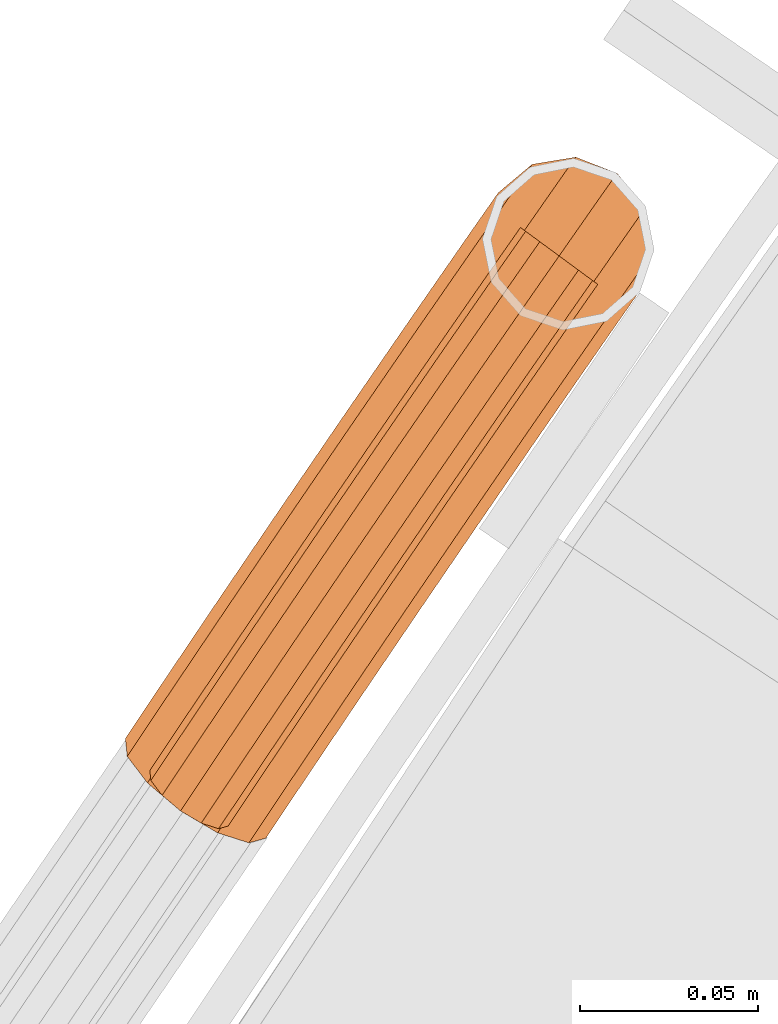
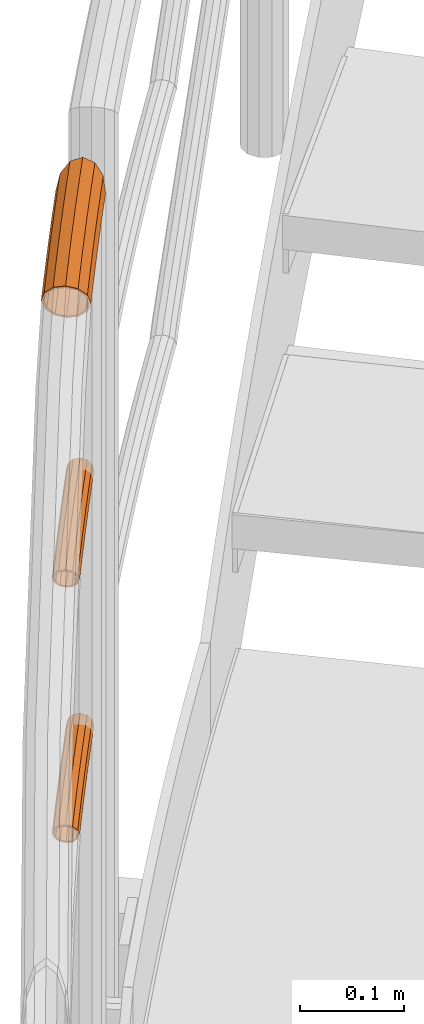
# One storey, part 63 of 126: 3 proxies.
"""IFC2X3 building model written with IfcOpenShell, lengths in millimetres."""

from ifc_helpers import new_model, si_unit, origin, origin_with_axes, place, context, project, spatial, faceted_brep, material, element, save


model = new_model("IFC2X3")

# Units and contexts
context_of_model_1 = context(None, 3, precision=0.1, world=origin())
context_of_model_2 = context(None, 3, precision=0.1, world=origin())
ifc_project = project(units=[si_unit("LENGTHUNIT", "METRE", prefix="MILLI"), si_unit("AREAUNIT", "SQUARE_METRE", prefix="CENTI"), si_unit("VOLUMEUNIT", "CUBIC_METRE", prefix="CENTI"), si_unit("MASSUNIT", "GRAM", prefix="KILO")], contexts=[context_of_model_1, context_of_model_2])

# Site, building, storey
site_placement = place(None, origin_with_axes())
site = spatial("IfcSite", under=ifc_project, at=site_placement, CompositionType="ELEMENT")
building_placement = place(site_placement, origin_with_axes())
building = spatial("IfcBuilding", under=site, at=building_placement, CompositionType="ELEMENT")
storey_placement = place(building_placement, origin_with_axes())
storey = spatial("IfcBuildingStorey", under=building, at=storey_placement, CompositionType="ELEMENT")

# Proxies
ifc_material = material(Name="S235JRG2")
proxy_1_placement = place(storey_placement, origin_with_axes())
element("IfcBuildingElementProxy", 1, at=proxy_1_placement, inside=storey, material=ifc_material, Name="HANDLAUF", context=context_of_model_2, shape_type="Brep", body=[
    faceted_brep([(765.4792, 13098.595, 9410.6145), (769.622, 13095.69, 9405.5548), (768.4581, 13102.827, 9410.6145), (760.5916, 13112.63, 9413.85), (755.5925, 13105.527, 9413.85), (749.0, 13117.14, 9410.6145), (745.7058, 13112.46, 9410.6145), (740.9116, 13115.821, 9404.7592), (746.7293, 13111.742, 9408.4494), (743.7727, 13113.815, 9404.8385), (748.7608, 13114.628, 9408.4494), (759.1524, 13110.585, 9411.35), (755.5925, 13105.527, 9411.35), (766.2046, 13101.797, 9408.4494), (764.4558, 13099.312, 9408.4494), (766.8879, 13097.607, 9405.479), (718.0512, 13093.958, 9389.7), (727.2731, 13107.159, 9389.7), (722.963, 13095.339, 9377.625), (720.7068, 13092.11, 9377.625), (723.857, 13089.917, 9373.787), (755.0391, 13068.215, 9377.625), (752.6425, 13069.883, 9374.7051), (756.668, 13070.546, 9377.625), (766.1923, 13078.53, 9389.7), (757.6947, 13066.366, 9389.7), (770.5024, 13090.35, 9401.775), (755.0391, 13068.215, 9401.775), (747.7838, 13073.264, 9410.6145), (737.8729, 13080.162, 9413.85), (727.9621, 13087.06, 9410.6145), (736.7975, 13115.143, 9401.775), (720.7068, 13092.11, 9401.775), (720.1032, 13092.53, 9389.7), (729.2876, 13105.677, 9389.7), (737.826, 13112.835, 9400.525), (722.4839, 13090.873, 9400.525), (728.9881, 13086.346, 9408.4494), (737.8729, 13080.162, 9411.35), (746.7578, 13073.978, 9408.4494), (768.0418, 13090.608, 9400.525), (753.262, 13069.451, 9400.525), (764.1778, 13080.012, 9389.7), (755.6427, 13067.795, 9389.7), (755.6395, 13072.855, 9378.875), (753.262, 13069.451, 9378.875), (749.7641, 13071.886, 9374.6133), (722.4839, 13090.873, 9378.875), (726.5885, 13088.016, 9373.8741), (725.4236, 13095.081, 9378.875), (703.0343, 13066.623, 9377.625), (700.3723, 13068.462, 9389.7), (725.0364, 13082.841, 9368.7855), (710.3071, 13061.599, 9368.7855), (732.9227, 13073.023, 9365.55), (720.242, 13054.736, 9365.55), (744.4977, 13068.525, 9368.7855), (730.1769, 13047.872, 9368.7855), (737.4497, 13042.848, 9377.625), (740.1118, 13041.009, 9389.7), (737.4497, 13042.848, 9401.775), (730.1769, 13047.872, 9410.6145), (720.242, 13054.736, 9413.85), (710.3071, 13061.599, 9410.6145), (703.0343, 13066.623, 9401.775), (704.8156, 13065.393, 9400.525), (702.4292, 13067.041, 9389.7), (711.3356, 13060.888, 9408.4494), (720.242, 13054.736, 9411.35), (729.1484, 13048.583, 9408.4494), (735.6684, 13044.079, 9400.525), (738.0549, 13042.43, 9389.7), (735.6684, 13044.079, 9378.875), (744.7246, 13071.046, 9370.9506), (729.1484, 13048.583, 9370.9506), (734.3478, 13075.078, 9368.05), (720.242, 13054.736, 9368.05), (727.2779, 13083.88, 9370.9506), (711.3356, 13060.888, 9370.9506), (704.8156, 13065.393, 9378.875), (685.4509, 13041.075, 9377.625), (682.7824, 13042.905, 9389.7), (692.7412, 13036.076, 9368.7855), (702.7, 13029.248, 9365.55), (712.6587, 13022.419, 9368.7855), (719.9491, 13017.42, 9377.625), (722.6175, 13015.591, 9389.7), (719.9491, 13017.42, 9401.775), (712.6587, 13022.419, 9410.6145), (702.7, 13029.248, 9413.85), (692.7412, 13036.076, 9410.6145), (685.4509, 13041.075, 9401.775), (687.2365, 13039.851, 9400.525), (684.8443, 13041.491, 9389.7), (693.7721, 13035.369, 9408.4494), (702.7, 13029.248, 9411.35), (711.6278, 13023.126, 9408.4494), (718.1634, 13018.645, 9400.525), (720.5557, 13017.004, 9389.7), (718.1634, 13018.645, 9378.875), (711.6278, 13023.126, 9370.9506), (702.7, 13029.248, 9368.05), (693.7721, 13035.369, 9370.9506), (687.2365, 13039.851, 9378.875), (667.9567, 13015.466, 9377.625), (665.2819, 13017.286, 9389.7), (675.2644, 13010.492, 9368.7855), (685.247, 13003.699, 9365.55), (695.2295, 12996.905, 9368.7855), (702.5373, 12991.932, 9377.625), (705.2121, 12990.111, 9389.7), (702.5373, 12991.932, 9401.775), (695.2295, 12996.905, 9410.6145), (685.247, 13003.699, 9413.85), (675.2644, 13010.492, 9410.6145), (667.9567, 13015.466, 9401.775), (669.7466, 13014.248, 9400.525), (667.3487, 13015.879, 9389.7), (676.2978, 13009.789, 9408.4494), (685.247, 13003.699, 9411.35), (694.1961, 12997.608, 9408.4494), (700.7474, 12993.15, 9400.525), (703.1453, 12991.518, 9389.7), (700.7474, 12993.15, 9378.875), (694.1961, 12997.608, 9370.9506), (685.247, 13003.699, 9368.05), (676.2978, 13009.789, 9370.9506), (669.7466, 13014.248, 9378.875), (650.552, 12989.796, 9377.625), (647.8709, 12991.607, 9389.7), (657.8771, 12984.848, 9368.7855), (667.8833, 12978.089, 9365.55), (677.8895, 12971.33, 9368.7855), (685.2145, 12966.382, 9377.625), (687.8957, 12964.571, 9389.7), (685.2145, 12966.382, 9401.775), (677.8895, 12971.33, 9410.6145), (667.8833, 12978.089, 9413.85), (657.8771, 12984.848, 9410.6145), (650.552, 12989.796, 9401.775), (652.3462, 12988.584, 9400.525), (649.9426, 12990.207, 9389.7), (658.9129, 12984.148, 9408.4494), (667.8833, 12978.089, 9411.35), (676.8536, 12972.03, 9408.4494), (683.4204, 12967.594, 9400.525), (685.824, 12965.97, 9389.7), (683.4204, 12967.594, 9378.875), (676.8536, 12972.03, 9370.9506), (667.8833, 12978.089, 9368.05), (658.9129, 12984.148, 9370.9506), (652.3462, 12988.584, 9378.875), (633.2371, 12964.065, 9377.625), (630.5496, 12965.866, 9389.7), (640.5794, 12959.143, 9368.7855), (650.6091, 12952.419, 9365.55), (660.6388, 12945.695, 9368.7855), (667.9811, 12940.772, 9377.625), (670.6686, 12938.971, 9389.7), (667.9811, 12940.772, 9401.775), (660.6388, 12945.695, 9410.6145), (650.6091, 12952.419, 9413.85), (640.5794, 12959.143, 9410.6145), (633.2371, 12964.065, 9401.775), (635.0354, 12962.859, 9400.525), (632.6262, 12964.474, 9389.7), (641.6176, 12958.446, 9408.4494), (650.6091, 12952.419, 9411.35), (659.6005, 12946.391, 9408.4494), (666.1828, 12941.978, 9400.525), (668.592, 12940.363, 9389.7), (666.1828, 12941.978, 9378.875), (659.6005, 12946.391, 9370.9506), (650.6091, 12952.419, 9368.05), (641.6176, 12958.446, 9370.9506), (635.0354, 12962.859, 9378.875), (627.5154, 12955.498, 9377.625), (622.7547, 12954.195, 9389.7), (636.2765, 12952.7, 9368.7855), (646.6904, 12946.551, 9365.55), (655.9669, 12938.699, 9368.7855), (661.6201, 12931.248, 9377.625), (662.1355, 12926.194, 9389.7), (657.3748, 12924.892, 9401.775), (648.6137, 12927.69, 9410.6145), (638.1998, 12933.838, 9413.85), (628.9233, 12941.69, 9410.6145), (623.2701, 12949.141, 9401.775), (625.255, 12948.215, 9400.525), (624.7931, 12952.746, 9389.7), (630.3231, 12941.535, 9408.4494), (638.6392, 12934.496, 9411.35), (647.9751, 12928.984, 9408.4494), (655.8293, 12926.476, 9400.525), (660.0971, 12927.644, 9389.7), (659.6351, 12932.174, 9378.875), (654.5671, 12938.854, 9370.9506), (646.251, 12945.893, 9368.05), (636.915, 12951.405, 9370.9506), (629.0609, 12953.913, 9378.875)], [[[0, 1, 2]], [[0, 2, 3, 4]], [[4, 3, 5, 6]], [[6, 5, 7]], [[8, 9, 10]], [[8, 10, 11, 12]], [[12, 11, 13, 14]], [[14, 13, 15]], [[16, 17, 18, 19]], [[19, 18, 20]], [[21, 22, 23]], [[21, 23, 24, 25]], [[25, 24, 26, 27]], [[0, 28, 27, 26, 1]], [[0, 4, 29, 28]], [[4, 6, 30, 29]], [[31, 32, 30, 6, 7]], [[16, 32, 31, 17]], [[33, 34, 35, 36]], [[35, 9, 8, 37, 36]], [[8, 12, 38, 37]], [[12, 14, 39, 38]], [[14, 15, 40, 41, 39]], [[41, 40, 42, 43]], [[43, 42, 44, 45]], [[45, 44, 46]], [[47, 48, 49]], [[33, 47, 49, 34]], [[16, 19, 50, 51]], [[19, 20, 52, 53, 50]], [[53, 52, 54, 55]], [[55, 54, 56, 57]], [[56, 22, 21, 58, 57]], [[21, 25, 59, 58]], [[25, 27, 60, 59]], [[27, 28, 61, 60]], [[28, 29, 62, 61]], [[29, 30, 63, 62]], [[30, 32, 64, 63]], [[32, 16, 51, 64]], [[33, 36, 65, 66]], [[36, 37, 67, 65]], [[37, 38, 68, 67]], [[38, 39, 69, 68]], [[39, 41, 70, 69]], [[41, 43, 71, 70]], [[43, 45, 72, 71]], [[73, 74, 72, 45, 46]], [[74, 73, 75, 76]], [[76, 75, 77, 78]], [[47, 79, 78, 77, 48]], [[47, 33, 66, 79]], [[51, 50, 80, 81]], [[50, 53, 82, 80]], [[53, 55, 83, 82]], [[55, 57, 84, 83]], [[57, 58, 85, 84]], [[58, 59, 86, 85]], [[59, 60, 87, 86]], [[60, 61, 88, 87]], [[61, 62, 89, 88]], [[62, 63, 90, 89]], [[63, 64, 91, 90]], [[64, 51, 81, 91]], [[66, 65, 92, 93]], [[65, 67, 94, 92]], [[67, 68, 95, 94]], [[68, 69, 96, 95]], [[69, 70, 97, 96]], [[70, 71, 98, 97]], [[71, 72, 99, 98]], [[72, 74, 100, 99]], [[74, 76, 101, 100]], [[76, 78, 102, 101]], [[78, 79, 103, 102]], [[79, 66, 93, 103]], [[81, 80, 104, 105]], [[80, 82, 106, 104]], [[82, 83, 107, 106]], [[83, 84, 108, 107]], [[84, 85, 109, 108]], [[85, 86, 110, 109]], [[86, 87, 111, 110]], [[87, 88, 112, 111]], [[88, 89, 113, 112]], [[89, 90, 114, 113]], [[90, 91, 115, 114]], [[91, 81, 105, 115]], [[93, 92, 116, 117]], [[92, 94, 118, 116]], [[94, 95, 119, 118]], [[95, 96, 120, 119]], [[96, 97, 121, 120]], [[97, 98, 122, 121]], [[98, 99, 123, 122]], [[99, 100, 124, 123]], [[100, 101, 125, 124]], [[101, 102, 126, 125]], [[102, 103, 127, 126]], [[103, 93, 117, 127]], [[105, 104, 128, 129]], [[104, 106, 130, 128]], [[106, 107, 131, 130]], [[107, 108, 132, 131]], [[108, 109, 133, 132]], [[109, 110, 134, 133]], [[110, 111, 135, 134]], [[111, 112, 136, 135]], [[112, 113, 137, 136]], [[113, 114, 138, 137]], [[114, 115, 139, 138]], [[115, 105, 129, 139]], [[117, 116, 140, 141]], [[116, 118, 142, 140]], [[118, 119, 143, 142]], [[119, 120, 144, 143]], [[120, 121, 145, 144]], [[121, 122, 146, 145]], [[122, 123, 147, 146]], [[123, 124, 148, 147]], [[124, 125, 149, 148]], [[125, 126, 150, 149]], [[126, 127, 151, 150]], [[127, 117, 141, 151]], [[129, 128, 152, 153]], [[128, 130, 154, 152]], [[130, 131, 155, 154]], [[131, 132, 156, 155]], [[132, 133, 157, 156]], [[133, 134, 158, 157]], [[134, 135, 159, 158]], [[135, 136, 160, 159]], [[136, 137, 161, 160]], [[137, 138, 162, 161]], [[138, 139, 163, 162]], [[139, 129, 153, 163]], [[141, 140, 164, 165]], [[140, 142, 166, 164]], [[142, 143, 167, 166]], [[143, 144, 168, 167]], [[144, 145, 169, 168]], [[145, 146, 170, 169]], [[146, 147, 171, 170]], [[147, 148, 172, 171]], [[148, 149, 173, 172]], [[149, 150, 174, 173]], [[150, 151, 175, 174]], [[151, 141, 165, 175]], [[152, 176, 177, 153]], [[152, 154, 178, 176]], [[154, 155, 179, 178]], [[155, 156, 180, 179]], [[156, 157, 181, 180]], [[157, 158, 182, 181]], [[158, 159, 183, 182]], [[159, 160, 184, 183]], [[160, 161, 185, 184]], [[161, 162, 186, 185]], [[162, 163, 187, 186]], [[153, 177, 187, 163]], [[164, 188, 189, 165]], [[164, 166, 190, 188]], [[166, 167, 191, 190]], [[167, 168, 192, 191]], [[168, 169, 193, 192]], [[169, 170, 194, 193]], [[170, 171, 195, 194]], [[171, 172, 196, 195]], [[172, 173, 197, 196]], [[173, 174, 198, 197]], [[174, 175, 199, 198]], [[165, 189, 199, 175]], [[17, 31, 7, 5, 3, 2, 1, 26, 24, 23, 22, 56, 54, 52, 20, 18], [10, 9, 35, 34, 49, 48, 77, 75, 73, 46, 44, 42, 40, 15, 13, 11]], [[185, 186, 187, 177, 176, 178, 179, 180, 181, 182, 183, 184], [188, 190, 191, 192, 193, 194, 195, 196, 197, 198, 199, 189]]]),
])
proxy_2_placement = place(storey_placement, origin_with_axes())
element("IfcBuildingElementProxy", 2, at=proxy_2_placement, inside=storey, material=ifc_material, context=context_of_model_2, shape_type="Brep", body=[
    faceted_brep([(726.8335, 13087.845, 9066.8551), (733.5177, 13097.414, 9066.8551), (734.9696, 13096.346, 9060.1301), (728.3125, 13086.816, 9060.1301), (738.9365, 13093.428, 9055.207), (732.3532, 13084.004, 9055.207), (744.3554, 13089.442, 9053.4051), (737.8729, 13080.162, 9053.4051), (749.7743, 13085.456, 9055.207), (743.3927, 13076.321, 9055.207), (753.7411, 13082.538, 9060.1301), (747.4334, 13073.508, 9060.1301), (755.1931, 13081.469, 9066.8551), (748.9124, 13072.479, 9066.8551), (753.7411, 13082.538, 9073.5801), (747.4334, 13073.508, 9073.5801), (749.7743, 13085.456, 9078.5031), (743.3927, 13076.321, 9078.5031), (744.3554, 13089.442, 9080.3051), (737.8729, 13080.162, 9080.3051), (738.9365, 13093.428, 9078.5031), (732.3532, 13084.004, 9078.5031), (734.9696, 13096.346, 9073.5801), (728.3125, 13086.816, 9073.5801), (728.4751, 13086.703, 9066.8551), (735.1292, 13096.228, 9066.8551), (736.3653, 13095.319, 9072.5801), (729.7342, 13085.827, 9072.5801), (739.7423, 13092.835, 9076.7711), (733.174, 13083.433, 9076.7711), (744.3554, 13089.442, 9078.3051), (737.8729, 13080.162, 9078.3051), (748.9685, 13086.048, 9076.7711), (742.5719, 13076.892, 9076.7711), (752.3455, 13083.564, 9072.5801), (746.0117, 13074.498, 9072.5801), (753.5816, 13082.655, 9066.8551), (747.2708, 13073.621, 9066.8551), (752.3455, 13083.564, 9061.1301), (746.0117, 13074.498, 9061.1301), (748.9685, 13086.048, 9056.9391), (742.5719, 13076.892, 9056.9391), (744.3554, 13089.442, 9055.4051), (737.8729, 13080.162, 9055.4051), (739.7423, 13092.835, 9056.9391), (733.174, 13083.433, 9056.9391), (736.3653, 13095.319, 9061.1301), (729.7342, 13085.827, 9061.1301), (710.6584, 13061.356, 9060.1301), (709.1758, 13062.38, 9066.8551), (714.7089, 13058.558, 9055.207), (720.242, 13054.736, 9053.4051), (725.7751, 13050.913, 9055.207), (729.8256, 13048.115, 9060.1301), (731.3082, 13047.091, 9066.8551), (729.8256, 13048.115, 9073.5801), (725.7751, 13050.913, 9078.5031), (720.242, 13054.736, 9080.3051), (714.7089, 13058.558, 9078.5031), (710.6584, 13061.356, 9073.5801), (712.0835, 13060.372, 9072.5801), (710.8214, 13061.244, 9066.8551), (715.5317, 13057.99, 9076.7711), (720.242, 13054.736, 9078.3051), (724.9524, 13051.482, 9076.7711), (728.4005, 13049.1, 9072.5801), (729.6627, 13048.228, 9066.8551), (728.4005, 13049.1, 9061.1301), (724.9524, 13051.482, 9056.9391), (720.242, 13054.736, 9055.4051), (715.5317, 13057.99, 9056.9391), (712.0835, 13060.372, 9061.1301), (693.0933, 13035.835, 9060.1301), (691.6072, 13036.854, 9066.8551), (697.1536, 13033.051, 9055.207), (702.7, 13029.248, 9053.4051), (708.2464, 13025.445, 9055.207), (712.3066, 13022.661, 9060.1301), (713.7928, 13021.642, 9066.8551), (712.3066, 13022.661, 9073.5801), (708.2464, 13025.445, 9078.5031), (702.7, 13029.248, 9080.3051), (697.1536, 13033.051, 9078.5031), (693.0933, 13035.835, 9073.5801), (694.5218, 13034.855, 9072.5801), (693.2567, 13035.723, 9066.8551), (697.9783, 13032.485, 9076.7711), (702.7, 13029.248, 9078.3051), (707.4216, 13026.01, 9076.7711), (710.8781, 13023.64, 9072.5801), (712.1433, 13022.773, 9066.8551), (710.8781, 13023.64, 9061.1301), (707.4216, 13026.01, 9056.9391), (702.7, 13029.248, 9055.4051), (697.9783, 13032.485, 9056.9391), (694.5218, 13034.855, 9061.1301), (675.6174, 13010.252, 9060.1301), (674.1277, 13011.266, 9066.8551), (679.6873, 13007.482, 9055.207), (685.247, 13003.699, 9053.4051), (690.8066, 12999.915, 9055.207), (694.8766, 12997.145, 9060.1301), (696.3663, 12996.131, 9066.8551), (694.8766, 12997.145, 9073.5801), (690.8066, 12999.915, 9078.5031), (685.247, 13003.699, 9080.3051), (679.6873, 13007.482, 9078.5031), (675.6174, 13010.252, 9073.5801), (677.0493, 13009.278, 9072.5801), (675.7811, 13010.141, 9066.8551), (680.5141, 13006.92, 9076.7711), (685.247, 13003.699, 9078.3051), (689.9799, 13000.478, 9076.7711), (693.4446, 12998.12, 9072.5801), (694.7128, 12997.257, 9066.8551), (693.4446, 12998.12, 9061.1301), (689.9799, 13000.478, 9056.9391), (685.247, 13003.699, 9055.4051), (680.5141, 13006.92, 9056.9391), (677.0493, 13009.278, 9061.1301), (658.2309, 12984.609, 9060.1301), (656.7377, 12985.617, 9066.8551), (662.3105, 12981.853, 9055.207), (667.8833, 12978.089, 9053.4051), (673.4561, 12974.325, 9055.207), (677.5357, 12971.569, 9060.1301), (679.0289, 12970.56, 9066.8551), (677.5357, 12971.569, 9073.5801), (673.4561, 12974.325, 9078.5031), (667.8833, 12978.089, 9080.3051), (662.3105, 12981.853, 9078.5031), (658.2309, 12984.609, 9073.5801), (659.6662, 12983.639, 9072.5801), (658.395, 12984.498, 9066.8551), (663.1391, 12981.293, 9076.7711), (667.8833, 12978.089, 9078.3051), (672.6274, 12974.884, 9076.7711), (676.1004, 12972.539, 9072.5801), (677.3716, 12971.68, 9066.8551), (676.1004, 12972.539, 9061.1301), (672.6274, 12974.884, 9056.9391), (667.8833, 12978.089, 9055.4051), (663.1391, 12981.293, 9056.9391), (659.6662, 12983.639, 9061.1301), (640.934, 12958.905, 9060.1301), (639.4372, 12959.908, 9066.8551), (645.0232, 12956.163, 9055.207), (650.6091, 12952.419, 9053.4051), (656.195, 12948.674, 9055.207), (660.2842, 12945.933, 9060.1301), (661.7809, 12944.929, 9066.8551), (660.2842, 12945.933, 9073.5801), (656.195, 12948.674, 9078.5031), (650.6091, 12952.419, 9080.3051), (645.0232, 12956.163, 9078.5031), (640.934, 12958.905, 9073.5801), (642.3727, 12957.94, 9072.5801), (641.0985, 12958.794, 9066.8551), (645.8538, 12955.607, 9076.7711), (650.6091, 12952.419, 9078.3051), (655.3644, 12949.231, 9076.7711), (658.8455, 12946.897, 9072.5801), (660.1197, 12946.043, 9066.8551), (658.8455, 12946.897, 9061.1301), (655.3644, 12949.231, 9056.9391), (650.6091, 12952.419, 9055.4051), (645.8538, 12955.607, 9056.9391), (642.3727, 12957.94, 9061.1301), (632.2537, 12945.908, 9060.1301), (629.6021, 12945.182, 9066.8551), (637.1332, 12944.35, 9055.207), (642.9331, 12940.925, 9053.4051), (648.0995, 12936.552, 9055.207), (651.2478, 12932.402, 9060.1301), (651.5346, 12929.587, 9066.8551), (648.883, 12928.862, 9073.5801), (644.0035, 12930.42, 9078.5031), (638.2036, 12933.844, 9080.3051), (633.0372, 12938.217, 9078.5031), (629.8889, 12942.367, 9073.5801), (631.4769, 12941.626, 9072.5801), (631.2327, 12944.022, 9066.8551), (634.1571, 12938.093, 9076.7711), (638.5552, 12934.37, 9078.3051), (643.4927, 12931.455, 9076.7711), (647.6466, 12930.129, 9072.5801), (649.904, 12930.747, 9066.8551), (649.6598, 12933.143, 9061.1301), (646.9796, 12936.676, 9056.9391), (642.5815, 12940.399, 9055.4051), (637.644, 12943.314, 9056.9391), (633.4901, 12944.64, 9061.1301)], [[[0, 1, 2, 3]], [[3, 2, 4, 5]], [[5, 4, 6, 7]], [[7, 6, 8, 9]], [[9, 8, 10, 11]], [[11, 10, 12, 13]], [[13, 12, 14, 15]], [[15, 14, 16, 17]], [[17, 16, 18, 19]], [[19, 18, 20, 21]], [[21, 20, 22, 23]], [[0, 23, 22, 1]], [[24, 25, 26, 27]], [[27, 26, 28, 29]], [[29, 28, 30, 31]], [[31, 30, 32, 33]], [[33, 32, 34, 35]], [[35, 34, 36, 37]], [[37, 36, 38, 39]], [[39, 38, 40, 41]], [[41, 40, 42, 43]], [[43, 42, 44, 45]], [[45, 44, 46, 47]], [[24, 47, 46, 25]], [[0, 3, 48, 49]], [[3, 5, 50, 48]], [[5, 7, 51, 50]], [[7, 9, 52, 51]], [[9, 11, 53, 52]], [[11, 13, 54, 53]], [[13, 15, 55, 54]], [[15, 17, 56, 55]], [[17, 19, 57, 56]], [[19, 21, 58, 57]], [[21, 23, 59, 58]], [[23, 0, 49, 59]], [[24, 27, 60, 61]], [[27, 29, 62, 60]], [[29, 31, 63, 62]], [[31, 33, 64, 63]], [[33, 35, 65, 64]], [[35, 37, 66, 65]], [[37, 39, 67, 66]], [[39, 41, 68, 67]], [[41, 43, 69, 68]], [[43, 45, 70, 69]], [[45, 47, 71, 70]], [[47, 24, 61, 71]], [[49, 48, 72, 73]], [[48, 50, 74, 72]], [[50, 51, 75, 74]], [[51, 52, 76, 75]], [[52, 53, 77, 76]], [[53, 54, 78, 77]], [[54, 55, 79, 78]], [[55, 56, 80, 79]], [[56, 57, 81, 80]], [[57, 58, 82, 81]], [[58, 59, 83, 82]], [[59, 49, 73, 83]], [[61, 60, 84, 85]], [[60, 62, 86, 84]], [[62, 63, 87, 86]], [[63, 64, 88, 87]], [[64, 65, 89, 88]], [[65, 66, 90, 89]], [[66, 67, 91, 90]], [[67, 68, 92, 91]], [[68, 69, 93, 92]], [[69, 70, 94, 93]], [[70, 71, 95, 94]], [[71, 61, 85, 95]], [[73, 72, 96, 97]], [[72, 74, 98, 96]], [[74, 75, 99, 98]], [[75, 76, 100, 99]], [[76, 77, 101, 100]], [[77, 78, 102, 101]], [[78, 79, 103, 102]], [[79, 80, 104, 103]], [[80, 81, 105, 104]], [[81, 82, 106, 105]], [[82, 83, 107, 106]], [[83, 73, 97, 107]], [[85, 84, 108, 109]], [[84, 86, 110, 108]], [[86, 87, 111, 110]], [[87, 88, 112, 111]], [[88, 89, 113, 112]], [[89, 90, 114, 113]], [[90, 91, 115, 114]], [[91, 92, 116, 115]], [[92, 93, 117, 116]], [[93, 94, 118, 117]], [[94, 95, 119, 118]], [[95, 85, 109, 119]], [[97, 96, 120, 121]], [[96, 98, 122, 120]], [[98, 99, 123, 122]], [[99, 100, 124, 123]], [[100, 101, 125, 124]], [[101, 102, 126, 125]], [[102, 103, 127, 126]], [[103, 104, 128, 127]], [[104, 105, 129, 128]], [[105, 106, 130, 129]], [[106, 107, 131, 130]], [[107, 97, 121, 131]], [[109, 108, 132, 133]], [[108, 110, 134, 132]], [[110, 111, 135, 134]], [[111, 112, 136, 135]], [[112, 113, 137, 136]], [[113, 114, 138, 137]], [[114, 115, 139, 138]], [[115, 116, 140, 139]], [[116, 117, 141, 140]], [[117, 118, 142, 141]], [[118, 119, 143, 142]], [[119, 109, 133, 143]], [[121, 120, 144, 145]], [[120, 122, 146, 144]], [[122, 123, 147, 146]], [[123, 124, 148, 147]], [[124, 125, 149, 148]], [[125, 126, 150, 149]], [[126, 127, 151, 150]], [[127, 128, 152, 151]], [[128, 129, 153, 152]], [[129, 130, 154, 153]], [[130, 131, 155, 154]], [[131, 121, 145, 155]], [[133, 132, 156, 157]], [[132, 134, 158, 156]], [[134, 135, 159, 158]], [[135, 136, 160, 159]], [[136, 137, 161, 160]], [[137, 138, 162, 161]], [[138, 139, 163, 162]], [[139, 140, 164, 163]], [[140, 141, 165, 164]], [[141, 142, 166, 165]], [[142, 143, 167, 166]], [[143, 133, 157, 167]], [[144, 168, 169, 145]], [[144, 146, 170, 168]], [[146, 147, 171, 170]], [[147, 148, 172, 171]], [[148, 149, 173, 172]], [[149, 150, 174, 173]], [[150, 151, 175, 174]], [[151, 152, 176, 175]], [[152, 153, 177, 176]], [[153, 154, 178, 177]], [[154, 155, 179, 178]], [[145, 169, 179, 155]], [[156, 180, 181, 157]], [[156, 158, 182, 180]], [[158, 159, 183, 182]], [[159, 160, 184, 183]], [[160, 161, 185, 184]], [[161, 162, 186, 185]], [[162, 163, 187, 186]], [[163, 164, 188, 187]], [[164, 165, 189, 188]], [[165, 166, 190, 189]], [[166, 167, 191, 190]], [[157, 181, 191, 167]], [[6, 4, 2, 1, 22, 20, 18, 16, 14, 12, 10, 8], [26, 25, 46, 44, 42, 40, 38, 36, 34, 32, 30, 28]], [[177, 178, 179, 169, 168, 170, 171, 172, 173, 174, 175, 176], [180, 182, 183, 184, 185, 186, 187, 188, 189, 190, 191, 181]]]),
])
proxy_3_placement = place(storey_placement, origin_with_axes())
element("IfcBuildingElementProxy", 3, at=proxy_3_placement, inside=storey, material=ifc_material, context=context_of_model_2, shape_type="Brep", body=[
    faceted_brep([(726.8335, 13087.845, 8766.8551), (733.5177, 13097.414, 8766.8551), (734.9696, 13096.346, 8760.1301), (728.3125, 13086.816, 8760.1301), (738.9365, 13093.428, 8755.207), (732.3532, 13084.004, 8755.207), (744.3554, 13089.442, 8753.4051), (737.8729, 13080.162, 8753.4051), (749.7743, 13085.456, 8755.207), (743.3927, 13076.321, 8755.207), (753.7411, 13082.538, 8760.1301), (747.4334, 13073.508, 8760.1301), (755.1931, 13081.469, 8766.8551), (748.9124, 13072.479, 8766.8551), (753.7411, 13082.538, 8773.5801), (747.4334, 13073.508, 8773.5801), (749.7743, 13085.456, 8778.5031), (743.3927, 13076.321, 8778.5031), (744.3554, 13089.442, 8780.3051), (737.8729, 13080.162, 8780.3051), (738.9365, 13093.428, 8778.5031), (732.3532, 13084.004, 8778.5031), (734.9696, 13096.346, 8773.5801), (728.3125, 13086.816, 8773.5801), (728.4751, 13086.703, 8766.8551), (735.1292, 13096.228, 8766.8551), (736.3653, 13095.319, 8772.5801), (729.7342, 13085.827, 8772.5801), (739.7423, 13092.835, 8776.7711), (733.174, 13083.433, 8776.7711), (744.3554, 13089.442, 8778.3051), (737.8729, 13080.162, 8778.3051), (748.9685, 13086.048, 8776.7711), (742.5719, 13076.892, 8776.7711), (752.3455, 13083.564, 8772.5801), (746.0117, 13074.498, 8772.5801), (753.5816, 13082.655, 8766.8551), (747.2708, 13073.621, 8766.8551), (752.3455, 13083.564, 8761.1301), (746.0117, 13074.498, 8761.1301), (748.9685, 13086.048, 8756.9391), (742.5719, 13076.892, 8756.9391), (744.3554, 13089.442, 8755.4051), (737.8729, 13080.162, 8755.4051), (739.7423, 13092.835, 8756.9391), (733.174, 13083.433, 8756.9391), (736.3653, 13095.319, 8761.1301), (729.7342, 13085.827, 8761.1301), (710.6584, 13061.356, 8760.1301), (709.1758, 13062.38, 8766.8551), (714.7089, 13058.558, 8755.207), (720.242, 13054.736, 8753.4051), (725.7751, 13050.913, 8755.207), (729.8256, 13048.115, 8760.1301), (731.3082, 13047.091, 8766.8551), (729.8256, 13048.115, 8773.5801), (725.7751, 13050.913, 8778.5031), (720.242, 13054.736, 8780.3051), (714.7089, 13058.558, 8778.5031), (710.6584, 13061.356, 8773.5801), (712.0835, 13060.372, 8772.5801), (710.8214, 13061.244, 8766.8551), (715.5317, 13057.99, 8776.7711), (720.242, 13054.736, 8778.3051), (724.9524, 13051.482, 8776.7711), (728.4005, 13049.1, 8772.5801), (729.6627, 13048.228, 8766.8551), (728.4005, 13049.1, 8761.1301), (724.9524, 13051.482, 8756.9391), (720.242, 13054.736, 8755.4051), (715.5317, 13057.99, 8756.9391), (712.0835, 13060.372, 8761.1301), (693.0933, 13035.835, 8760.1301), (691.6072, 13036.854, 8766.8551), (697.1536, 13033.051, 8755.207), (702.7, 13029.248, 8753.4051), (708.2464, 13025.445, 8755.207), (712.3066, 13022.661, 8760.1301), (713.7928, 13021.642, 8766.8551), (712.3066, 13022.661, 8773.5801), (708.2464, 13025.445, 8778.5031), (702.7, 13029.248, 8780.3051), (697.1536, 13033.051, 8778.5031), (693.0933, 13035.835, 8773.5801), (694.5218, 13034.855, 8772.5801), (693.2567, 13035.723, 8766.8551), (697.9783, 13032.485, 8776.7711), (702.7, 13029.248, 8778.3051), (707.4216, 13026.01, 8776.7711), (710.8781, 13023.64, 8772.5801), (712.1433, 13022.773, 8766.8551), (710.8781, 13023.64, 8761.1301), (707.4216, 13026.01, 8756.9391), (702.7, 13029.248, 8755.4051), (697.9783, 13032.485, 8756.9391), (694.5218, 13034.855, 8761.1301), (675.6174, 13010.252, 8760.1301), (674.1277, 13011.266, 8766.8551), (679.6873, 13007.482, 8755.207), (685.247, 13003.699, 8753.4051), (690.8066, 12999.915, 8755.207), (694.8766, 12997.145, 8760.1301), (696.3663, 12996.131, 8766.8551), (694.8766, 12997.145, 8773.5801), (690.8066, 12999.915, 8778.5031), (685.247, 13003.699, 8780.3051), (679.6873, 13007.482, 8778.5031), (675.6174, 13010.252, 8773.5801), (677.0493, 13009.278, 8772.5801), (675.7811, 13010.141, 8766.8551), (680.5141, 13006.92, 8776.7711), (685.247, 13003.699, 8778.3051), (689.9799, 13000.478, 8776.7711), (693.4446, 12998.12, 8772.5801), (694.7128, 12997.257, 8766.8551), (693.4446, 12998.12, 8761.1301), (689.9799, 13000.478, 8756.9391), (685.247, 13003.699, 8755.4051), (680.5141, 13006.92, 8756.9391), (677.0493, 13009.278, 8761.1301), (658.2309, 12984.609, 8760.1301), (656.7377, 12985.617, 8766.8551), (662.3105, 12981.853, 8755.207), (667.8833, 12978.089, 8753.4051), (673.4561, 12974.325, 8755.207), (677.5357, 12971.569, 8760.1301), (679.0289, 12970.56, 8766.8551), (677.5357, 12971.569, 8773.5801), (673.4561, 12974.325, 8778.5031), (667.8833, 12978.089, 8780.3051), (662.3105, 12981.853, 8778.5031), (658.2309, 12984.609, 8773.5801), (659.6662, 12983.639, 8772.5801), (658.395, 12984.498, 8766.8551), (663.1391, 12981.293, 8776.7711), (667.8833, 12978.089, 8778.3051), (672.6274, 12974.884, 8776.7711), (676.1004, 12972.539, 8772.5801), (677.3716, 12971.68, 8766.8551), (676.1004, 12972.539, 8761.1301), (672.6274, 12974.884, 8756.9391), (667.8833, 12978.089, 8755.4051), (663.1391, 12981.293, 8756.9391), (659.6662, 12983.639, 8761.1301), (640.934, 12958.905, 8760.1301), (639.4372, 12959.908, 8766.8551), (645.0232, 12956.163, 8755.207), (650.6091, 12952.419, 8753.4051), (656.195, 12948.674, 8755.207), (660.2842, 12945.933, 8760.1301), (661.7809, 12944.929, 8766.8551), (660.2842, 12945.933, 8773.5801), (656.195, 12948.674, 8778.5031), (650.6091, 12952.419, 8780.3051), (645.0232, 12956.163, 8778.5031), (640.934, 12958.905, 8773.5801), (642.3727, 12957.94, 8772.5801), (641.0985, 12958.794, 8766.8551), (645.8538, 12955.607, 8776.7711), (650.6091, 12952.419, 8778.3051), (655.3644, 12949.231, 8776.7711), (658.8455, 12946.897, 8772.5801), (660.1197, 12946.043, 8766.8551), (658.8455, 12946.897, 8761.1301), (655.3644, 12949.231, 8756.9391), (650.6091, 12952.419, 8755.4051), (645.8538, 12955.607, 8756.9391), (642.3727, 12957.94, 8761.1301), (632.2537, 12945.908, 8760.1301), (629.6021, 12945.182, 8766.8551), (637.1332, 12944.35, 8755.207), (642.9331, 12940.925, 8753.4051), (648.0995, 12936.552, 8755.207), (651.2478, 12932.402, 8760.1301), (651.5346, 12929.587, 8766.8551), (648.883, 12928.862, 8773.5801), (644.0035, 12930.42, 8778.5031), (638.2036, 12933.844, 8780.3051), (633.0372, 12938.217, 8778.5031), (629.8889, 12942.367, 8773.5801), (631.4769, 12941.626, 8772.5801), (631.2327, 12944.022, 8766.8551), (634.1571, 12938.093, 8776.7711), (638.5552, 12934.37, 8778.3051), (643.4927, 12931.455, 8776.7711), (647.6466, 12930.129, 8772.5801), (649.904, 12930.747, 8766.8551), (649.6598, 12933.143, 8761.1301), (646.9796, 12936.676, 8756.9391), (642.5815, 12940.399, 8755.4051), (637.644, 12943.314, 8756.9391), (633.49, 12944.64, 8761.1301)], [[[0, 1, 2, 3]], [[3, 2, 4, 5]], [[5, 4, 6, 7]], [[7, 6, 8, 9]], [[9, 8, 10, 11]], [[11, 10, 12, 13]], [[13, 12, 14, 15]], [[15, 14, 16, 17]], [[17, 16, 18, 19]], [[19, 18, 20, 21]], [[21, 20, 22, 23]], [[0, 23, 22, 1]], [[24, 25, 26, 27]], [[27, 26, 28, 29]], [[29, 28, 30, 31]], [[31, 30, 32, 33]], [[33, 32, 34, 35]], [[35, 34, 36, 37]], [[37, 36, 38, 39]], [[39, 38, 40, 41]], [[41, 40, 42, 43]], [[43, 42, 44, 45]], [[45, 44, 46, 47]], [[24, 47, 46, 25]], [[0, 3, 48, 49]], [[3, 5, 50, 48]], [[5, 7, 51, 50]], [[7, 9, 52, 51]], [[9, 11, 53, 52]], [[11, 13, 54, 53]], [[13, 15, 55, 54]], [[15, 17, 56, 55]], [[17, 19, 57, 56]], [[19, 21, 58, 57]], [[21, 23, 59, 58]], [[23, 0, 49, 59]], [[24, 27, 60, 61]], [[27, 29, 62, 60]], [[29, 31, 63, 62]], [[31, 33, 64, 63]], [[33, 35, 65, 64]], [[35, 37, 66, 65]], [[37, 39, 67, 66]], [[39, 41, 68, 67]], [[41, 43, 69, 68]], [[43, 45, 70, 69]], [[45, 47, 71, 70]], [[47, 24, 61, 71]], [[49, 48, 72, 73]], [[48, 50, 74, 72]], [[50, 51, 75, 74]], [[51, 52, 76, 75]], [[52, 53, 77, 76]], [[53, 54, 78, 77]], [[54, 55, 79, 78]], [[55, 56, 80, 79]], [[56, 57, 81, 80]], [[57, 58, 82, 81]], [[58, 59, 83, 82]], [[59, 49, 73, 83]], [[61, 60, 84, 85]], [[60, 62, 86, 84]], [[62, 63, 87, 86]], [[63, 64, 88, 87]], [[64, 65, 89, 88]], [[65, 66, 90, 89]], [[66, 67, 91, 90]], [[67, 68, 92, 91]], [[68, 69, 93, 92]], [[69, 70, 94, 93]], [[70, 71, 95, 94]], [[71, 61, 85, 95]], [[73, 72, 96, 97]], [[72, 74, 98, 96]], [[74, 75, 99, 98]], [[75, 76, 100, 99]], [[76, 77, 101, 100]], [[77, 78, 102, 101]], [[78, 79, 103, 102]], [[79, 80, 104, 103]], [[80, 81, 105, 104]], [[81, 82, 106, 105]], [[82, 83, 107, 106]], [[83, 73, 97, 107]], [[85, 84, 108, 109]], [[84, 86, 110, 108]], [[86, 87, 111, 110]], [[87, 88, 112, 111]], [[88, 89, 113, 112]], [[89, 90, 114, 113]], [[90, 91, 115, 114]], [[91, 92, 116, 115]], [[92, 93, 117, 116]], [[93, 94, 118, 117]], [[94, 95, 119, 118]], [[95, 85, 109, 119]], [[97, 96, 120, 121]], [[96, 98, 122, 120]], [[98, 99, 123, 122]], [[99, 100, 124, 123]], [[100, 101, 125, 124]], [[101, 102, 126, 125]], [[102, 103, 127, 126]], [[103, 104, 128, 127]], [[104, 105, 129, 128]], [[105, 106, 130, 129]], [[106, 107, 131, 130]], [[107, 97, 121, 131]], [[109, 108, 132, 133]], [[108, 110, 134, 132]], [[110, 111, 135, 134]], [[111, 112, 136, 135]], [[112, 113, 137, 136]], [[113, 114, 138, 137]], [[114, 115, 139, 138]], [[115, 116, 140, 139]], [[116, 117, 141, 140]], [[117, 118, 142, 141]], [[118, 119, 143, 142]], [[119, 109, 133, 143]], [[121, 120, 144, 145]], [[120, 122, 146, 144]], [[122, 123, 147, 146]], [[123, 124, 148, 147]], [[124, 125, 149, 148]], [[125, 126, 150, 149]], [[126, 127, 151, 150]], [[127, 128, 152, 151]], [[128, 129, 153, 152]], [[129, 130, 154, 153]], [[130, 131, 155, 154]], [[131, 121, 145, 155]], [[133, 132, 156, 157]], [[132, 134, 158, 156]], [[134, 135, 159, 158]], [[135, 136, 160, 159]], [[136, 137, 161, 160]], [[137, 138, 162, 161]], [[138, 139, 163, 162]], [[139, 140, 164, 163]], [[140, 141, 165, 164]], [[141, 142, 166, 165]], [[142, 143, 167, 166]], [[143, 133, 157, 167]], [[144, 168, 169, 145]], [[144, 146, 170, 168]], [[146, 147, 171, 170]], [[147, 148, 172, 171]], [[148, 149, 173, 172]], [[149, 150, 174, 173]], [[150, 151, 175, 174]], [[151, 152, 176, 175]], [[152, 153, 177, 176]], [[153, 154, 178, 177]], [[154, 155, 179, 178]], [[145, 169, 179, 155]], [[156, 180, 181, 157]], [[156, 158, 182, 180]], [[158, 159, 183, 182]], [[159, 160, 184, 183]], [[160, 161, 185, 184]], [[161, 162, 186, 185]], [[162, 163, 187, 186]], [[163, 164, 188, 187]], [[164, 165, 189, 188]], [[165, 166, 190, 189]], [[166, 167, 191, 190]], [[157, 181, 191, 167]], [[6, 4, 2, 1, 22, 20, 18, 16, 14, 12, 10, 8], [26, 25, 46, 44, 42, 40, 38, 36, 34, 32, 30, 28]], [[177, 178, 179, 169, 168, 170, 171, 172, 173, 174, 175, 176], [180, 182, 183, 184, 185, 186, 187, 188, 189, 190, 191, 181]]]),
])

save(model, "model.ifc")
